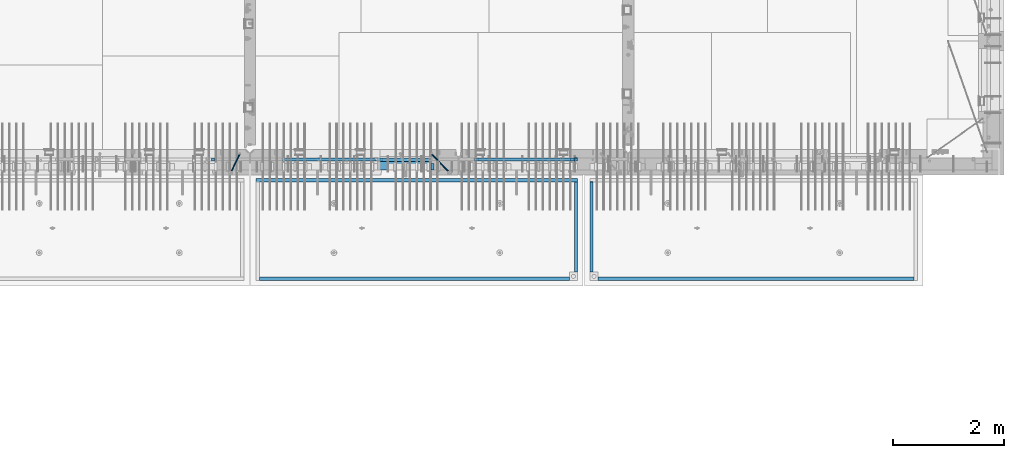
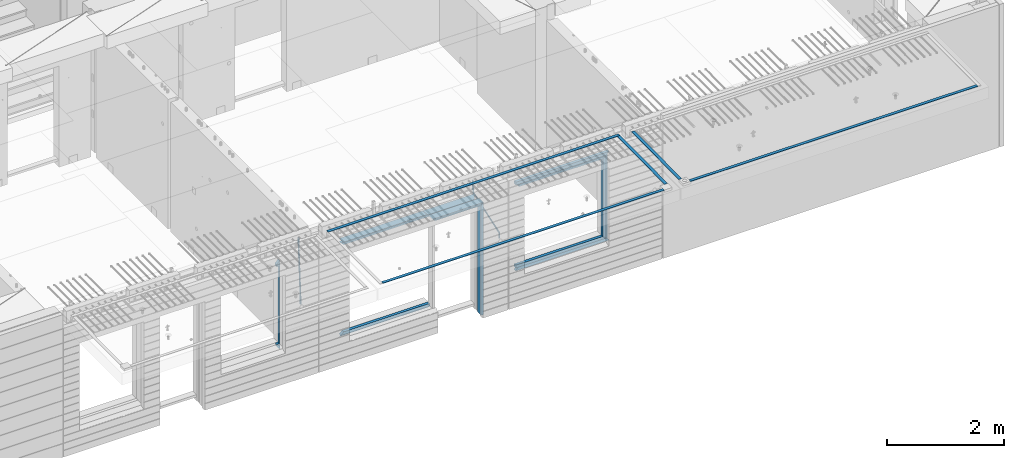
# One storey, part 92 of 341: 22 beams, 5 elements without a shape of their own.
"""IFC2X3 building model written with IfcOpenShell, lengths in millimetres."""

from ifc_helpers import new_model, si_unit, frame, origin_with_axes, place, context, subcontext, project, spatial, faceted_brep, material, type_object, element, aggregate, save


model = new_model("IFC2X3")

# Units and contexts
model_context = context("Model", 3, precision=1e-05, world=origin_with_axes())
body_context = subcontext(model_context, "Body", "Model", "MODEL_VIEW")
ifc_project = project(units=[si_unit("LENGTHUNIT", "METRE", prefix="MILLI"), si_unit("AREAUNIT", "SQUARE_METRE"), si_unit("VOLUMEUNIT", "CUBIC_METRE"), si_unit("MASSUNIT", "GRAM", prefix="KILO"), si_unit("TIMEUNIT", "SECOND"), si_unit("PLANEANGLEUNIT", "RADIAN"), si_unit("SOLIDANGLEUNIT", "STERADIAN"), si_unit("THERMODYNAMICTEMPERATUREUNIT", "DEGREE_CELSIUS"), si_unit("LUMINOUSINTENSITYUNIT", "LUMEN")], contexts=[model_context])

# Site, building, storey
site_placement = place(None, origin_with_axes())
site = spatial("IfcSite", under=ifc_project, at=site_placement, CompositionType="ELEMENT")
building_placement = place(site_placement, origin_with_axes())
building = spatial("IfcBuilding", under=site, at=building_placement, CompositionType="ELEMENT")
storey_placement = place(building_placement, origin_with_axes())
storey = spatial("IfcBuildingStorey", under=building, at=storey_placement, Name="5", CompositionType="ELEMENT", Elevation=0.0)

# Assembly, beams
assembly_1_placement = place(storey_placement, origin_with_axes())
assembly_1 = element("IfcElementAssembly", 1, at=assembly_1_placement, inside=storey, AssemblyPlace="NOTDEFINED", PredefinedType="REINFORCEMENT_UNIT")
ifc_material_1 = material(Name="CONCRETE/C35/45")
beam_type_1 = type_object("IfcBeamType", PredefinedType="NOTDEFINED")
beam_1_placement = place(assembly_1_placement, frame((24034.9998642727, 7815.0, 96140.0), z_axis=(0.0, 0.0, -1.0), x_axis=(1.0, 0.0, 0.0)))
beam_1 = element("IfcBeam", 2, at=beam_1_placement, type_object=beam_type_1, material=ifc_material_1, Name="SK", context=body_context, shape_type="Brep", body=[
    faceted_brep([(70.0000000000164, -35.0, 35.0), (70.0000000000164, 35.0, 35.0), (0.0, -35.0, -35.0), (1039.99961853026, -35.0, -35.0), (980.889062997325, -35.0, 35.0), (980.889062997325, 35.0, 35.0)], [[[0, 1, 2]], [[0, 2, 3, 4]], [[1, 0, 4, 5]], [[2, 1, 5, 3]], [[4, 3, 5]]]),
])
ifc_material_2 = material(Name="TIMBER")
beam_type_2 = type_object("IfcBeamType", Name="50X150", PredefinedType="NOTDEFINED")
beam_2_placement = place(assembly_1_placement, frame((24104.9998642727, 7705.0, 96080.0), z_axis=(0.0, 0.0, -1.0), x_axis=(1.0, 0.0, 0.0)))
beam_2 = element("IfcBeam", 3, at=beam_2_placement, type_object=beam_type_2, material=ifc_material_2, ObjectType="50X150", context=body_context, shape_type="Brep", body=[
    faceted_brep([(50.0000000000036, -75.0, 25.0), (50.0000000000036, 75.0, 25.0), (0.0, 75.0, -25.0), (0.0, -75.0, -25.0), (1009.99961853027, -75.0, -25.0), (959.999618530259, -75.0, 25.0), (959.999618530259, 75.0, 25.0), (1009.99961853027, 75.0, -25.0)], [[[0, 1, 2, 3]], [[0, 3, 4, 5]], [[1, 0, 5, 6]], [[2, 1, 6, 7]], [[3, 2, 7, 4]], [[6, 5, 4, 7]]]),
])

# Assembly, beam
assembly_2_placement = place(storey_placement, origin_with_axes())
assembly_2 = element("IfcElementAssembly", 4, at=assembly_2_placement, inside=storey, AssemblyPlace="NOTDEFINED", PredefinedType="REINFORCEMENT_UNIT")
ifc_material_3 = material()
beam_type_3 = type_object("IfcBeamType", Name="D20", PredefinedType="NOTDEFINED")
beam_3_placement = place(assembly_2_placement, frame((21625.0073331492, 7924.99999997881, 96407.5), z_axis=(-0.000415599999849952, -0.999999913638316, 0.0), x_axis=(-6.05680000062309e-05, -4.00000390151988e-09, -0.999999998165759)))
beam_3 = element("IfcBeam", 5, at=beam_3_placement, type_object=beam_type_3, material=ifc_material_3, Name="JM20", ObjectType="D20", context=body_context, shape_type="Brep", body=[
    faceted_brep([(-0.00060564729210455, -9.99999998165731, 0.0), (-0.000428079845733009, -7.07106779890455, -7.07106781186667), (119.575515501536, -7.07830994756296, -7.07106481604933), (119.575337932896, -10.0072421307195, -3.43332612828817e-06), (0.0, 0.0, -10.0), (119.575943836026, -0.00724214867295814, -9.99999700418266), (0.00042843479604926, 7.07106779888636, -7.07106781186303), (119.57637202373, 7.06382565022977, -7.07106481604933), (0.00060564729210455, 9.99999998166459, 3.63797880709171e-12), (119.576549238118, 9.99275783300072, 2.99581552098971e-06), (0.000428079845733009, 7.07106779890819, 7.07106781186667), (119.576371669405, 7.06382565024978, 7.07107080768037), (0.0, 0.0, 10.0), (119.57594333493, -0.00724214864203532, 10.0000029958155), (-0.000428434810601175, -7.07106779888272, 7.07106781186667), (119.575515147211, -7.07830994754295, 7.07107080768037), (123.006973508192, -7.07825951346604, -6.96785036235087), (122.582196132164, -10.0072047447829, 0.090452766209637), (123.182421564867, -0.00718632049392909, -9.89150999405319), (123.005765870272, 7.06387605862983, -6.9678969281922), (122.5804889344, 9.99279518261392, 0.090375952400791), (122.155712218591, 7.06384995171538, 7.14866812117907), (121.980264161975, -0.00722324126036256, 10.0723277528814), (122.156919856599, -7.07828562038412, 7.14871468701676), (235.904703171851, -7.06860422895625, -0.169508357435916), (235.479926262604, -9.99754169577864, 6.88878701985595), (236.080151695453, 0.002465748351824, -3.09317573838871), (235.903496467319, 7.07353134315781, -0.16957042179456), (235.478219724217, 10.0024582304504, 6.88869924890878), (235.053442814489, 7.07352076285679, 13.9469946275131), (234.877994290917, 0.00245078554871725, 16.8706620084649), (235.05464951905, -7.06861480925727, 13.9470566918726), (247.69730842374, 6.49890140729985, 1.5904257279044), (247.708271375333, -0.564091162203113, -1.35790592567901), (246.351191555892, -7.5775885142175, 1.3894260566567), (244.421027918448, -10.4331790195793, 8.22307186000126), (243.04844414418, -7.45809648886643, 15.1399744532118), (243.037481192529, -0.395103919359826, 18.0883061067871), (244.394561011999, 6.61839343264, 15.3409741244495), (246.324724649443, 9.47398393802723, 8.50732832109588), (256.620302657771, 7.90789673379186, 11.9850227549905), (258.892076862918, 4.79603600307382, 5.371853429986), (253.26121545503, 5.26966351612282, 18.3359992487194), (250.782522980895, -1.57322241172369, 20.7044670154446), (250.636209669712, -8.61229127897968, 17.7030097594688), (252.907983874131, -11.724152010418, 11.0898404357176), (256.267071077629, -9.08591879203959, 4.7388639407518), (258.745763551793, -2.24303286420036, 2.37039617402661), (1008.47908473376, -166.485147783689, 337.205828025195), (1005.11999753102, -169.123381001344, 343.556804518913), (1010.95777720789, -159.642261855857, 334.837360258474), (1011.10409051905, -152.60319298859, 337.838817514449), (1008.83231631388, -149.491332257865, 344.451986839456), (1005.47322911114, -152.129565475519, 350.802963333173), (1002.99453663701, -158.972451403351, 353.171431099895), (1002.84822332587, -166.011520270618, 350.169973843918), (1010.17087503639, -166.839152352099, 337.953575170377), (1008.40147312843, -169.810024819315, 345.007169854448), (1011.47638800017, -159.75078038171, 335.066578819891), (1011.55326023143, -152.697181073247, 338.037344110582), (1010.35646101969, -149.810257238067, 345.125637025791), (1008.58705911171, -152.781129705283, 352.179231709861), (1007.28154614793, -159.869501675676, 355.066228060347), (1007.20467391667, -166.923100984135, 352.095462769656), (1012.05411677422, -166.839038287919, 337.953575122971), (1012.05429688386, -169.809803575103, 345.007169762499), (1012.05368737834, -159.750745415844, 335.066578805359), (1012.05326023052, -152.697150789249, 338.037344097996), (1012.05308554815, -149.81015447692, 345.125636983083), (1012.05326565779, -152.780919764096, 352.179231622609), (1012.05369505366, -159.869212636178, 355.066227940223), (1012.05412220149, -166.92280726277, 352.095462647586), (1117.510115663, -166.832651029355, 337.953572468433), (1117.51029577265, -169.803416316539, 345.00716710796), (1117.50968626713, -159.744358157277, 335.06657615082), (1117.50925911931, -152.690763530685, 338.037341443456), (1117.50908443694, -149.803767218353, 345.125634328543), (1117.50926454658, -152.774532505533, 352.17922896807), (1117.50969394245, -159.862825377615, 355.066225285684), (1117.51012109026, -166.916420004207, 352.095459993046)], [[[0, 1, 2, 3]], [[1, 4, 5, 2]], [[4, 6, 7, 5]], [[6, 8, 9, 7]], [[8, 10, 11, 9]], [[10, 12, 13, 11]], [[12, 14, 15, 13]], [[14, 0, 3, 15]], [[14, 12, 10, 8, 6, 4, 1, 0]], [[3, 2, 16, 17]], [[2, 5, 18, 16]], [[5, 7, 19, 18]], [[7, 9, 20, 19]], [[9, 11, 21, 20]], [[11, 13, 22, 21]], [[13, 15, 23, 22]], [[15, 3, 17, 23]], [[17, 16, 24, 25]], [[16, 18, 26, 24]], [[18, 19, 27, 26]], [[19, 20, 28, 27]], [[20, 21, 29, 28]], [[21, 22, 30, 29]], [[22, 23, 31, 30]], [[23, 17, 25, 31]], [[26, 27, 32, 33]], [[24, 26, 33, 34]], [[25, 24, 34, 35]], [[31, 25, 35, 36]], [[30, 31, 36, 37]], [[29, 30, 37, 38]], [[28, 29, 38, 39]], [[27, 28, 39, 32]], [[39, 40, 41, 32]], [[38, 42, 40, 39]], [[37, 43, 42, 38]], [[36, 44, 43, 37]], [[35, 45, 44, 36]], [[34, 46, 45, 35]], [[33, 47, 46, 34]], [[32, 41, 47, 33]], [[45, 46, 48, 49]], [[46, 47, 50, 48]], [[47, 41, 51, 50]], [[41, 40, 52, 51]], [[40, 42, 53, 52]], [[42, 43, 54, 53]], [[43, 44, 55, 54]], [[44, 45, 49, 55]], [[49, 48, 56, 57]], [[48, 50, 58, 56]], [[50, 51, 59, 58]], [[51, 52, 60, 59]], [[52, 53, 61, 60]], [[53, 54, 62, 61]], [[54, 55, 63, 62]], [[55, 49, 57, 63]], [[57, 56, 64, 65]], [[56, 58, 66, 64]], [[58, 59, 67, 66]], [[59, 60, 68, 67]], [[60, 61, 69, 68]], [[61, 62, 70, 69]], [[62, 63, 71, 70]], [[63, 57, 65, 71]], [[65, 64, 72, 73]], [[64, 66, 74, 72]], [[66, 67, 75, 74]], [[67, 68, 76, 75]], [[68, 69, 77, 76]], [[69, 70, 78, 77]], [[70, 71, 79, 78]], [[71, 65, 73, 79]], [[74, 75, 76, 77, 78, 79, 73, 72]]]),
])

# Beam
beam_4_placement = place(assembly_1_placement, frame((25075.0293329014, 7924.99999993642, 96407.5), z_axis=(-0.000415599999849952, -0.999999913638316, 0.0), x_axis=(-0.000242263999929879, 0.0, -0.999999970654077)))
beam_4 = element("IfcBeam", 6, at=beam_4_placement, type_object=beam_type_3, material=ifc_material_3, Name="JM20", ObjectType="D20", context=body_context, shape_type="Brep", body=[
    faceted_brep([(-0.00060564729210455, -9.99999998165731, 0.0), (-0.000428079845733009, -7.07106779890455, -7.07106781186667), (119.575515501536, -7.07830994756296, -7.07106481604933), (119.575337932896, -10.0072421307195, -3.43332612828817e-06), (0.0, 0.0, -10.0), (119.575943836026, -0.00724214867295814, -9.99999700418266), (0.00042843479604926, 7.07106779888636, -7.07106781186303), (119.57637202373, 7.06382565022977, -7.07106481604933), (0.00060564729210455, 9.99999998166459, 3.63797880709171e-12), (119.576549238118, 9.99275783300072, 2.99581552098971e-06), (0.000428079845733009, 7.07106779890819, 7.07106781186667), (119.576371669405, 7.06382565024978, 7.07107080768037), (0.0, 0.0, 10.0), (119.57594333493, -0.00724214864203532, 10.0000029958155), (-0.000428434810601175, -7.07106779888272, 7.07106781186667), (119.575515147211, -7.07830994754295, 7.07107080768037), (123.008274907785, -7.07795567963694, -6.96780325792497), (122.584029738471, -10.0069316327917, 0.0905081323508057), (123.182440752484, -0.00686994861462153, -9.89150922917906), (123.004503280346, 7.06417944043824, -6.96794247666548), (122.578695849254, 9.99306765562687, 0.0903112464729929), (122.15445067735, 7.0640917031651, 7.14862263591931), (121.980284832651, -0.0069940278553986, 10.072328607177), (122.158222304832, -7.07804341691372, 7.14876185467801), (233.088395941915, -7.04853267872386, -0.33914435535371), (232.664150764584, -9.97750862893736, 6.71916703474017), (233.262561786629, 0.0225530520438042, -3.26285032724809), (233.08462431423, 7.09360244138225, -0.339283575355694), (232.658816882788, 10.0224906572403, 6.71897014756632), (232.234571710651, 7.09351470543697, 13.777281537301), (232.060405865923, 0.0224289746693103, 16.7009875091953), (232.238343338337, -7.04862041468004, 13.7774207573038), (248.070459246126, -5.60737147376494, 1.85103242021069), (247.013897852143, -8.59717146491312, 8.81690765643543), (244.865343898215, -5.8339984379636, 15.6233189364948), (242.883391151001, 1.06351832306973, 18.2831628436061), (242.22904064988, 8.05490704629119, 15.2383388907911), (243.285602043848, 11.0447070374539, 8.27246365456904), (245.434155997835, 8.28153401051895, 1.46605237452331), (247.416108745019, 1.38401724946743, -1.19379153259433), (260.512945877912, 5.37327174938764, 3.16696371259513), (261.933955342625, -1.38459511741894, 6.46705632785779), (256.86166640259, 11.762316953962, 5.27098446848322), (253.118986913221, 14.0399244660766, 11.5466117722399), (251.477318295016, 10.8719026949148, 18.3176682617204), (252.898327759729, 4.11403582813364, 21.6177608769931), (256.54960723508, -2.27500937642981, 19.5137401211105), (260.292286730517, -4.55261688891915, 13.2381128181169), (1011.6899267952, 318.016952836686, 337.688913324002), (1010.04825817693, 314.848931065488, 344.459969813425), (1010.26891733034, 324.774819703332, 334.388820708672), (1006.61763785462, 331.163864907652, 336.492841464405), (1002.87495836492, 333.441472419578, 342.76846876801), (1001.23328974665, 330.273450648383, 349.539525257433), (1002.6542992115, 323.515583781733, 352.839617872763), (1006.30557868723, 317.12653857741, 350.73559711703), (1012.11607330808, 318.198494379605, 337.877173297548), (1011.23010097447, 315.352404773395, 344.982075913254), (1011.34812648257, 325.234570724882, 334.865586047124), (1009.37611333313, 332.338995712049, 337.711461129013), (1007.35521241752, 335.350093536494, 344.747723517063), (1006.46924008391, 332.504003930284, 351.85262613277), (1007.23718690944, 325.467927585003, 354.864213383194), (1009.20920005886, 318.363502597836, 352.018338301305), (1012.61607329341, 318.198615511596, 337.877173247205), (1012.61676345688, 315.352740711776, 344.982075773638), (1012.61436835937, 325.234877489685, 334.865585919631), (1012.61264738202, 332.339779807688, 337.71146080314), (1012.61191848651, 335.351367047057, 344.747722987787), (1012.61260864999, 332.505492247237, 351.852625514221), (1012.61431358402, 325.469230269144, 354.864212841793), (1012.61603456138, 318.364327951142, 352.018337958285), (1117.42297412557, 318.224006449098, 337.87716269464), (1117.42366428903, 315.378131649279, 344.982065221072), (1117.42126919153, 325.260268427191, 334.865575367066), (1117.41954821418, 332.365170745194, 337.711450250575), (1117.41881931867, 335.376757984559, 344.747712435222), (1117.41950948215, 332.530883184736, 351.852614961655), (1117.42121441617, 325.494621206646, 354.864202289227), (1117.42293539354, 318.389718888644, 352.018327405719)], [[[0, 1, 2, 3]], [[1, 4, 5, 2]], [[4, 6, 7, 5]], [[6, 8, 9, 7]], [[8, 10, 11, 9]], [[10, 12, 13, 11]], [[12, 14, 15, 13]], [[14, 0, 3, 15]], [[14, 12, 10, 8, 6, 4, 1, 0]], [[3, 2, 16, 17]], [[2, 5, 18, 16]], [[5, 7, 19, 18]], [[7, 9, 20, 19]], [[9, 11, 21, 20]], [[11, 13, 22, 21]], [[13, 15, 23, 22]], [[15, 3, 17, 23]], [[17, 16, 24, 25]], [[16, 18, 26, 24]], [[18, 19, 27, 26]], [[19, 20, 28, 27]], [[20, 21, 29, 28]], [[21, 22, 30, 29]], [[22, 23, 31, 30]], [[23, 17, 25, 31]], [[25, 24, 32, 33]], [[31, 25, 33, 34]], [[30, 31, 34, 35]], [[29, 30, 35, 36]], [[28, 29, 36, 37]], [[27, 28, 37, 38]], [[26, 27, 38, 39]], [[24, 26, 39, 32]], [[39, 40, 41, 32]], [[38, 42, 40, 39]], [[37, 43, 42, 38]], [[36, 44, 43, 37]], [[35, 45, 44, 36]], [[34, 46, 45, 35]], [[33, 47, 46, 34]], [[32, 41, 47, 33]], [[47, 41, 48, 49]], [[41, 40, 50, 48]], [[40, 42, 51, 50]], [[42, 43, 52, 51]], [[43, 44, 53, 52]], [[44, 45, 54, 53]], [[45, 46, 55, 54]], [[46, 47, 49, 55]], [[49, 48, 56, 57]], [[48, 50, 58, 56]], [[50, 51, 59, 58]], [[51, 52, 60, 59]], [[52, 53, 61, 60]], [[53, 54, 62, 61]], [[54, 55, 63, 62]], [[55, 49, 57, 63]], [[57, 56, 64, 65]], [[56, 58, 66, 64]], [[58, 59, 67, 66]], [[59, 60, 68, 67]], [[60, 61, 69, 68]], [[61, 62, 70, 69]], [[62, 63, 71, 70]], [[63, 57, 65, 71]], [[65, 64, 72, 73]], [[64, 66, 74, 72]], [[66, 67, 75, 74]], [[67, 68, 76, 75]], [[68, 69, 77, 76]], [[69, 70, 78, 77]], [[70, 71, 79, 78]], [[71, 65, 73, 79]], [[74, 75, 76, 77, 78, 79, 73, 72]]]),
])

# Assembly, beams
assembly_3_placement = place(storey_placement, origin_with_axes())
assembly_3 = element("IfcElementAssembly", 7, at=assembly_3_placement, inside=storey, AssemblyPlace="NOTDEFINED", PredefinedType="REINFORCEMENT_UNIT")
ifc_material_4 = material(Name="CONCRETE/Concrete_Undefined")
beam_type_4 = type_object("IfcBeamType", PredefinedType="NOTDEFINED")
beam_5_placement = place(assembly_3_placement, frame((27949.9413896323, 7420.0548526853, 96725.6636564041), z_axis=(3.20999999465459e-07, -0.00901957599816896, 0.999959322797038), x_axis=(3.55380000057318e-05, -0.999959322165559, -0.00901957600149657)))
beam_5 = element("IfcBeam", 8, at=beam_5_placement, type_object=beam_type_4, material=ifc_material_4, context=body_context, shape_type="Brep", body=[
    faceted_brep([(2.5465851649642e-11, 29.9999999999982, -4.99999999998545), (-2.91038304567337e-11, 29.9999999999982, 5.0), (1625.35189228369, 30.0000000000073, 5.0), (1625.35189228371, 30.0000000000073, -5.0), (-2.5465851649642e-11, -30.0000000000018, 5.0), (1625.35189228368, -29.9999999999927, 5.00000000001455), (2.72848410531878e-11, -30.0000000000018, -4.99999999998545), (1625.35189228371, -29.9999999999927, -4.99999999998545)], [[[0, 1, 2, 3]], [[1, 4, 5, 2]], [[4, 6, 7, 5]], [[6, 0, 3, 7]], [[5, 7, 3, 2]], [[6, 4, 1, 0]]]),
])
beam_6_placement = place(assembly_3_placement, frame((33750.1798578673, 5674.89208457699, 96711.2777998596), z_axis=(-0.00010875600001081, -1.00000033862182e-09, 0.999999994086066), x_axis=(-0.999999994070015, -5.66600000038745e-06, -0.000108756000006807)))
beam_6 = element("IfcBeam", 9, at=beam_6_placement, type_object=beam_type_4, material=ifc_material_4, context=body_context, shape_type="Brep", body=[
    faceted_brep([(2.5465851649642e-11, 29.9999999999982, -4.99999999998545), (-2.91038304567337e-11, 29.9999999999982, 5.0), (5682.56261276337, 30.0, 5.0), (5682.56261276337, 30.0, -5.0), (-2.5465851649642e-11, -30.0000000000018, 5.0), (5682.56261276337, -30.0, 5.0), (2.72848410531878e-11, -30.0000000000018, -4.99999999998545), (5682.56261276337, -30.0, -5.0)], [[[0, 1, 2, 3]], [[1, 4, 5, 2]], [[4, 6, 7, 5]], [[6, 0, 3, 7]], [[5, 7, 3, 2]], [[6, 4, 1, 0]]]),
])
aggregate(assembly_3, [beam_5, beam_6])

assembly_4_placement = place(storey_placement, origin_with_axes())
assembly_4 = element("IfcElementAssembly", 10, at=assembly_4_placement, inside=storey, AssemblyPlace="NOTDEFINED", PredefinedType="REINFORCEMENT_UNIT")
beam_7_placement = place(assembly_4_placement, frame((27670.0013901304, 7419.94686420498, 96725.2791047129), z_axis=(-7.99999906695021e-09, -0.0106298469955396, 0.99994350158039), x_axis=(-7.67999998664137e-07, -0.999943501580095, -0.0106298469955353)))
beam_7 = element("IfcBeam", 11, at=beam_7_placement, type_object=beam_type_4, material=ifc_material_4, context=body_context, shape_type="Brep", body=[
    faceted_brep([(2.5465851649642e-11, 29.9999999999982, -4.99999999998545), (-2.91038304567337e-11, 29.9999999999982, 5.0), (1625.17584384035, 29.9999999999964, 5.0), (1625.17584384035, 30.0000000000036, -4.99999999998545), (-2.5465851649642e-11, -30.0000000000018, 5.0), (1625.17584384035, -30.0, 5.0), (2.72848410531878e-11, -30.0000000000018, -4.99999999998545), (1625.17584384035, -29.9999999999964, -4.99999999998545)], [[[0, 1, 2, 3]], [[1, 4, 5, 2]], [[4, 6, 7, 5]], [[6, 0, 3, 7]], [[5, 7, 3, 2]], [[6, 4, 1, 0]]]),
])
beam_8_placement = place(assembly_4_placement, frame((27700.0033616247, 7449.93184428144, 96725.2788442816), z_axis=(6.6541999986247e-05, -1.00000033832184e-09, 0.999999997786081), x_axis=(-0.999999997707994, 1.24969999963762e-05, 6.65419999798477e-05)))
beam_8 = element("IfcBeam", 12, at=beam_8_placement, type_object=beam_type_4, material=ifc_material_4, context=body_context, shape_type="Brep", body=[
    faceted_brep([(2.5465851649642e-11, 29.9999999999982, -4.99999999998545), (-2.91038304567337e-11, 29.9999999999982, 5.0), (5780.0600107005, 30.0, 5.00000000001455), (5780.0600107005, 30.0000000000009, -5.0), (-2.5465851649642e-11, -30.0000000000018, 5.0), (5780.0600107005, -30.0000000000009, 5.00000000001455), (2.72848410531878e-11, -30.0000000000018, -4.99999999998545), (5780.0600107005, -30.0, -4.99999999998545)], [[[0, 1, 2, 3]], [[1, 4, 5, 2]], [[4, 6, 7, 5]], [[6, 0, 3, 7]], [[5, 7, 3, 2]], [[6, 4, 1, 0]]]),
])
beam_9_placement = place(assembly_4_placement, frame((21979.9397016438, 5674.8679591, 96709.8457712343), z_axis=(0.000327872000083623, 1.99999976807677e-09, 0.999999946249974), x_axis=(0.999999946233322, 5.77100000136594e-06, -0.000327872000077393)))
beam_9 = element("IfcBeam", 13, at=beam_9_placement, type_object=beam_type_4, material=ifc_material_4, context=body_context, shape_type="Brep", body=[
    faceted_brep([(2.5465851649642e-11, 29.9999999999982, -4.99999999998545), (-2.91038304567337e-11, 29.9999999999982, 5.0), (5570.052902922, 30.0000000000009, 5.00000000001455), (5570.05290292199, 30.0000000000009, -4.99999999998545), (-2.5465851649642e-11, -30.0000000000018, 5.0), (5570.052902922, -30.0, 5.00000000001455), (2.72848410531878e-11, -30.0000000000018, -4.99999999998545), (5570.05290292199, -30.0, -4.99999999998545)], [[[0, 1, 2, 3]], [[1, 4, 5, 2]], [[4, 6, 7, 5]], [[6, 0, 3, 7]], [[5, 7, 3, 2]], [[6, 4, 1, 0]]]),
])
aggregate(assembly_4, [beam_7, beam_8, beam_9])

# Beam
beam_type_5 = type_object("IfcBeamType", PredefinedType="NOTDEFINED")
beam_10_placement = place(assembly_2_placement, frame((21144.9998642727, 7820.0, 96175.0), z_axis=(-1.0, 3.00000001838171e-08, 0.0), x_axis=(0.0, 0.0, -1.0)))
beam_10 = element("IfcBeam", 14, at=beam_10_placement, type_object=beam_type_5, material=ifc_material_1, Name="SK", context=body_context, shape_type="Brep", body=[
    faceted_brep([(1740.94594594595, -30.0, 30.0), (1739.32432432432, 30.0, 30.0), (1739.32432432432, 30.0, -24.3243243243269), (1740.94594594595, -30.0, -25.9459459459504), (115.67567567568, 30.0, -24.3243243243269), (114.054054054053, -30.0, -25.9459459459504), (115.67567567568, 30.0, 30.0), (114.054054054053, -30.0, 30.0), (72.2635272671032, 30.0, 30.0), (72.2635272671032, -30.0, 30.0), (0.0, 30.0, -30.0), (0.0, -30.0, -30.0), (1855.0, -30.0, -30.0), (1782.73647273288, -30.0, 30.0), (1782.73647273287, 30.0, 30.0), (1855.0, 30.0, -30.0)], [[[0, 1, 2, 3]], [[3, 2, 4, 5]], [[5, 4, 6, 7]], [[7, 6, 8, 9]], [[10, 11, 9, 8]], [[0, 3, 5, 7, 9, 11, 12, 13]], [[1, 0, 13, 14]], [[10, 8, 6, 4, 2, 1, 14, 15]], [[15, 12, 11, 10]], [[15, 14, 13, 12]]]),
])

beam_11_placement = place(assembly_1_placement, frame((22384.9998642751, 7820.0, 96145.0), z_axis=(0.0, 0.0, -1.0), x_axis=(1.0, 0.0, 0.0)))
beam_11 = element("IfcBeam", 15, at=beam_11_placement, type_object=beam_type_5, material=ifc_material_1, Name="SK", context=body_context, shape_type="Brep", body=[
    faceted_brep([(1820.00000000026, -30.0, 30.0), (1820.00000000026, -30.0, -30.0), (1820.00000000026, 30.0, 30.0), (49.817662327685, -30.0, 30.0), (0.0, -30.0, -30.0), (49.817662327685, 30.0, 30.0)], [[[0, 1, 2]], [[1, 0, 3, 4]], [[2, 1, 4, 5]], [[0, 2, 5, 3]], [[4, 3, 5]]]),
])

beam_12_placement = place(assembly_1_placement, frame((22384.9998642751, 7820.0, 96085.0), z_axis=(0.0, 0.0, -1.0), x_axis=(1.0, 0.0, 0.0)))
beam_12 = element("IfcBeam", 16, at=beam_12_placement, type_object=beam_type_5, material=ifc_material_1, Name="SK", context=body_context, shape_type="Brep", body=[
    faceted_brep([(1820.00000000026, -30.0, -30.0), (1820.00000000026, 30.0, -30.0), (1820.00000000026, 30.0, 25.6756756756804), (1820.00000000026, -30.0, 24.0540540540678), (59.8219112435072, 30.0, 25.6756756756804), (58.0795254791192, -30.0, 24.0540540540533), (0.0, -30.0, -30.0), (0.0, 30.0, -30.0)], [[[0, 1, 2, 3]], [[3, 2, 4, 5]], [[0, 3, 5, 6]], [[6, 7, 1, 0]], [[2, 1, 7, 4]], [[4, 7, 6, 5]]]),
])

beam_13_placement = place(assembly_1_placement, frame((24144.9998642753, 7820.0, 94150.0), z_axis=(0.0, 0.0, 1.0), x_axis=(-1.0, 3.00000001838171e-08, 0.0)))
beam_13 = element("IfcBeam", 17, at=beam_13_placement, type_object=beam_type_5, material=ifc_material_1, Name="SK", context=body_context, shape_type="Brep", body=[
    faceted_brep([(0.0, -30.0, 30.0), (-5.28234522789717e-09, 30.0, 30.0), (0.0, -30.0, -30.0), (1710.18233767259, -30.0, 30.0), (1710.18233767259, 30.0, 30.0), (1760.00000000026, -30.0, -30.0)], [[[0, 1, 2]], [[1, 0, 3, 4]], [[2, 1, 4, 5]], [[0, 2, 5, 3]], [[4, 3, 5]]]),
])

beam_14_placement = place(assembly_1_placement, frame((24144.9998642753, 7820.0, 94210.0), z_axis=(0.0, 0.0, 1.0), x_axis=(-1.0, 3.00000001838171e-08, 0.0)))
beam_14 = element("IfcBeam", 18, at=beam_14_placement, type_object=beam_type_5, material=ifc_material_1, Name="SK", context=body_context, shape_type="Brep", body=[
    faceted_brep([(0.0, 30.0, -30.0), (0.0, -30.0, -30.0), (0.0, -30.0, 24.0540540540678), (0.0, 30.0, 25.6756756756804), (1700.17808875675, 30.0, 25.6756756756804), (1760.00000000026, 30.0, -30.0), (1760.00000000026, -30.0, -30.0), (1701.92047452114, -30.0, 24.0540540540533)], [[[0, 1, 2, 3]], [[0, 3, 4, 5]], [[1, 0, 5, 6]], [[2, 1, 6, 7]], [[3, 2, 7, 4]], [[6, 5, 4, 7]]]),
])

# Assembly, beams
assembly_5_placement = place(storey_placement, origin_with_axes())
assembly_5 = element("IfcElementAssembly", 19, at=assembly_5_placement, inside=storey, AssemblyPlace="NOTDEFINED", PredefinedType="REINFORCEMENT_UNIT")
beam_15_placement = place(assembly_5_placement, frame((25845.0006272121, 7820.0, 96145.0), z_axis=(0.0, 0.0, -1.0), x_axis=(1.0, 0.0, 0.0)))
beam_15 = element("IfcBeam", 20, at=beam_15_placement, type_object=beam_type_5, material=ifc_material_1, Name="SK", context=body_context, shape_type="Brep", body=[
    faceted_brep([(0.0, -30.0, -30.0), (0.0, -30.0, 30.0), (-5.28234522789717e-09, 30.0, 30.0), (0.0, 30.0, -30.0), (1849.99885559082, -30.0, -30.0), (1789.99885559081, -30.0, 30.0), (1789.99885559081, 30.0, 30.0), (1849.99885559082, 30.0, -30.0)], [[[0, 1, 2, 3]], [[1, 0, 4, 5]], [[2, 1, 5, 6]], [[3, 2, 6, 7]], [[0, 3, 7, 4]], [[6, 5, 4, 7]]]),
])
beam_16_placement = place(assembly_5_placement, frame((25905.0006272121, 7820.0, 96085.0), z_axis=(0.0, 0.0, -1.0), x_axis=(1.0, 0.0, 0.0)))
beam_16 = element("IfcBeam", 21, at=beam_16_placement, type_object=beam_type_5, material=ifc_material_1, Name="SK", context=body_context, shape_type="Brep", body=[
    faceted_brep([(1665.94480153677, -30.0, 24.0540540540533), (1664.32317991515, 30.0, 25.6756756756804), (0.0, 30.0, 25.6756756756804), (0.0, -30.0, 24.0540540540678), (0.0, 30.0, -30.0), (0.0, -30.0, -30.0), (1729.99885559082, -30.0, -30.0), (1665.94480153677, -30.0, 24.9034748914419), (1664.32317991515, 30.0, 26.293436281092), (1729.99885559082, 30.0, -30.0)], [[[0, 1, 2, 3]], [[4, 5, 3, 2]], [[0, 3, 5, 6, 7]], [[1, 0, 7, 8]], [[4, 2, 1, 8, 9]], [[5, 4, 9, 6]], [[8, 7, 6, 9]]]),
])
beam_17_placement = place(assembly_5_placement, frame((27664.9994828029, 7820.0, 96175.0), z_axis=(-1.0, 3.00000001838171e-08, 0.0), x_axis=(0.0, 0.0, -1.0)))
beam_17 = element("IfcBeam", 22, at=beam_17_placement, type_object=beam_type_5, material=ifc_material_1, Name="SK", context=body_context, shape_type="Brep", body=[
    faceted_brep([(60.0000000000073, 30.0, 30.0), (0.0, -30.0, -30.0), (60.0000000000073, -30.0, 30.0), (1855.0, -30.0, -30.0), (1795.00000000001, -30.0, 30.0), (1795.00000000001, 30.0, 30.0)], [[[0, 1, 2]], [[3, 4, 2, 1]], [[4, 5, 0, 2]], [[5, 3, 1, 0]], [[4, 3, 5]]]),
])
beam_18_placement = place(assembly_5_placement, frame((27694.9994828029, 7820.0, 94350.0), z_axis=(0.0, 0.0, 1.0), x_axis=(-1.0, 3.00000001838171e-08, 0.0)))
beam_18 = element("IfcBeam", 23, at=beam_18_placement, type_object=beam_type_5, material=ifc_material_1, Name="SK", context=body_context, shape_type="Brep", body=[
    faceted_brep([(1849.99885559082, 30.0, -30.0), (1800.18119326315, 30.0, 30.0), (1800.18119326315, -30.0, 30.0), (1849.99885559082, -30.0, -30.0), (0.0, -30.0, -30.0), (0.0, 30.0, -30.0), (60.0000000000073, 30.0, 30.0), (60.0000000000073, -30.0, 30.0)], [[[0, 1, 2, 3]], [[4, 5, 0, 3]], [[1, 0, 5, 6]], [[2, 1, 6, 7]], [[3, 2, 7, 4]], [[6, 5, 4, 7]]]),
])
beam_19_placement = place(assembly_5_placement, frame((27634.9994828029, 7820.0, 94410.0), z_axis=(0.0, 0.0, 1.0), x_axis=(-1.0, 3.00000001838171e-08, 0.0)))
beam_19 = element("IfcBeam", 24, at=beam_19_placement, type_object=beam_type_5, material=ifc_material_1, Name="SK", context=body_context, shape_type="Brep", body=[
    faceted_brep([(1785.94885559082, 30.0, 30.0), (1784.32432432432, 30.0, 30.0), (1785.94885559082, -30.0, 30.0), (1785.94885559082, -30.0, 24.0540519302303), (1784.32432432433, 30.0, 25.6756756756804), (65.6756756756768, 30.0, 25.6756756756804), (64.0540540540533, -30.0, 24.0540540540533), (1785.94885559082, -30.0, -30.0), (1785.94885559082, 30.0, -30.0), (0.0, -30.0, -30.0), (0.0, 30.0, -30.0), (65.6756756756768, 30.0, 26.293436281092), (64.0540540540533, -30.0, 24.9034748914419)], [[[0, 1, 2]], [[3, 4, 5, 6]], [[1, 4, 3, 2]], [[7, 8, 0, 2, 3]], [[8, 7, 9, 10]], [[5, 4, 1, 0, 8, 10, 11]], [[6, 5, 11, 12]], [[7, 3, 6, 12, 9]], [[9, 12, 11, 10]]]),
])

# Beam
beam_type_6 = type_object("IfcBeamType", PredefinedType="NOTDEFINED")
beam_20_placement = place(assembly_2_placement, frame((21139.9998642727, 7820.0, 96115.0), z_axis=(-1.0, 3.00000001838171e-08, 0.0), x_axis=(0.0, 0.0, -1.0)))
beam_20 = element("IfcBeam", 25, at=beam_20_placement, type_object=beam_type_6, material=ifc_material_1, Name="SK", context=body_context, shape_type="Brep", body=[
    faceted_brep([(1680.94594594595, -30.0, -30.9459459459504), (1679.32432432432, 30.0, -29.3243243243269), (55.6756756756804, 30.0, -29.3243243243269), (54.0540540540533, -30.0, -30.9459459459504), (55.6756756756804, 30.0, 24.8219112435145), (54.0540540540533, -30.0, 23.0795254791374), (0.0, 30.0, -35.0), (0.0, -30.0, -35.0), (1735.0, -30.0, -35.0), (1680.94594594595, -30.0, 23.0795254791337), (1679.32432432432, 30.0, 24.8219112435145), (1735.0, 30.0, -35.0)], [[[0, 1, 2, 3]], [[3, 2, 4, 5]], [[4, 6, 7, 5]], [[0, 3, 5, 7, 8, 9]], [[1, 0, 9, 10]], [[6, 4, 2, 1, 10, 11]], [[11, 8, 7, 6]], [[10, 9, 8, 11]]]),
])

aggregate(assembly_2, [beam_3, beam_10, beam_20])

beam_21_placement = place(assembly_5_placement, frame((27599.9994828029, 7820.0, 96115.0), z_axis=(-1.0, 3.00000001838171e-08, 0.0), x_axis=(0.0, 0.0, -1.0)))
beam_21 = element("IfcBeam", 26, at=beam_21_placement, type_object=beam_type_6, material=ifc_material_1, Name="SK", context=body_context, shape_type="Brep", body=[
    faceted_brep([(0.0, -30.0, -35.0), (54.9034748914273, -30.0, 29.0540540540533), (56.2934362811066, 30.0, 30.6756756756768), (0.0, 30.0, -35.0), (1735.0, -30.0, -35.0), (1680.09652510857, -30.0, 29.0540540540533), (1678.70656371891, 30.0, 30.6756756756768), (1735.0, 30.0, -35.0)], [[[0, 1, 2, 3]], [[1, 0, 4, 5]], [[2, 1, 5, 6]], [[3, 2, 6, 7]], [[7, 4, 0, 3]], [[4, 7, 6, 5]]]),
])

aggregate(assembly_5, [beam_15, beam_16, beam_17, beam_21, beam_18, beam_19])

beam_type_7 = type_object("IfcBeamType", Name="50X120", PredefinedType="NOTDEFINED")
beam_22_placement = place(assembly_1_placement, frame((25089.9994828029, 7690.0, 96105.0), z_axis=(-1.0, 3.00000001838171e-08, 0.0), x_axis=(0.0, 0.0, -1.0)))
beam_22 = element("IfcBeam", 27, at=beam_22_placement, type_object=beam_type_7, material=ifc_material_2, ObjectType="50X120", context=body_context, shape_type="Brep", body=[
    faceted_brep([(2345.0, -60.0, 25.0), (2345.0, -60.0, -25.0), (2345.0, 60.0, -25.0), (2345.0, 60.0, 25.0), (0.0, -60.0, -25.0), (0.0, 60.0, -25.0), (50.0000000000036, 60.0, 25.0), (50.0000000000036, -60.0, 25.0)], [[[0, 1, 2, 3]], [[4, 5, 2, 1]], [[3, 2, 5, 6]], [[0, 3, 6, 7]], [[1, 0, 7, 4]], [[5, 4, 7, 6]]]),
])

aggregate(assembly_1, [beam_4, beam_11, beam_12, beam_13, beam_14, beam_1, beam_2, beam_22])

save(model, "model.ifc")
